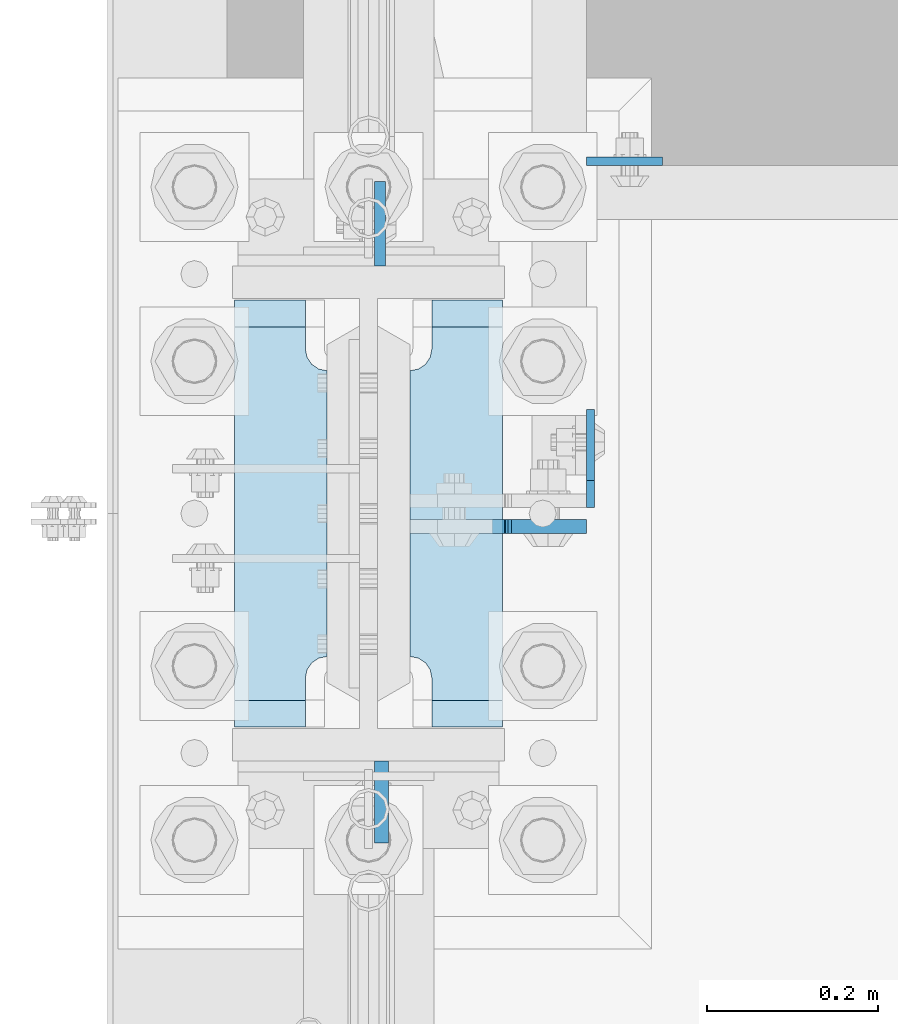
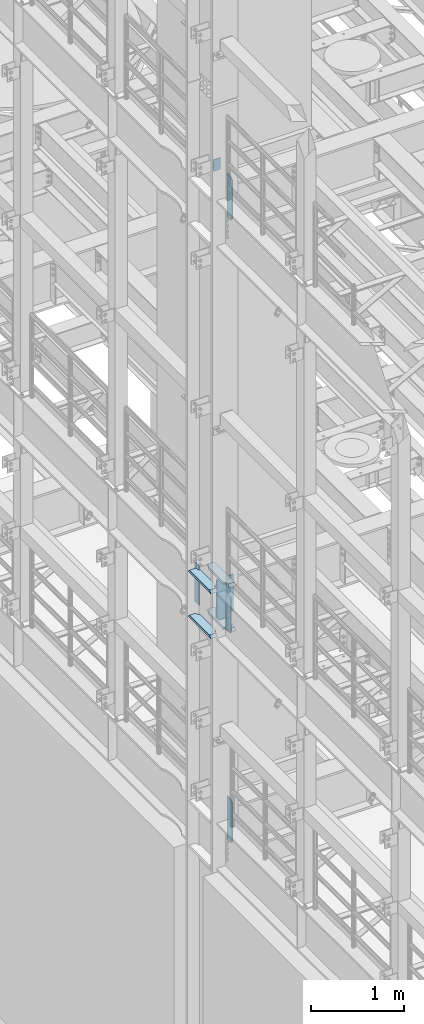
# One storey, part 1551 of 1876: 10 plates, 4 elements without a shape of their own.
"""IFC2X3 building model written with IfcOpenShell, lengths in millimetres."""

from ifc_helpers import new_model, si_unit, frame, origin_with_axes, place, context, subcontext, project, spatial, faceted_brep, material, type_object, element, aggregate, save


model = new_model("IFC2X3")

# Units and contexts
model_context = context("Model", 3, precision=1e-05, world=origin_with_axes())
body_context = subcontext(model_context, "Body", "Model", "MODEL_VIEW")
ifc_project = project(units=[si_unit("LENGTHUNIT", "METRE", prefix="MILLI"), si_unit("AREAUNIT", "SQUARE_METRE"), si_unit("VOLUMEUNIT", "CUBIC_METRE"), si_unit("MASSUNIT", "GRAM", prefix="KILO"), si_unit("TIMEUNIT", "SECOND"), si_unit("PLANEANGLEUNIT", "RADIAN"), si_unit("SOLIDANGLEUNIT", "STERADIAN"), si_unit("THERMODYNAMICTEMPERATUREUNIT", "DEGREE_CELSIUS"), si_unit("LUMINOUSINTENSITYUNIT", "LUMEN")], contexts=[model_context])

# Site, building, storey
site_placement = place(None, origin_with_axes())
site = spatial("IfcSite", under=ifc_project, at=site_placement, CompositionType="ELEMENT")
building_placement = place(site_placement, origin_with_axes())
building = spatial("IfcBuilding", under=site, at=building_placement, Name="Undefined", CompositionType="ELEMENT")
storey_placement = place(building_placement, origin_with_axes())
storey = spatial("IfcBuildingStorey", under=building, at=storey_placement, Name="Undefined", CompositionType="ELEMENT", Elevation=0.0)

# Assembly, plate
assembly_1_placement = place(storey_placement, origin_with_axes())
assembly_1 = element("IfcElementAssembly", 1, at=assembly_1_placement, inside=storey, Name="BEAM", AssemblyPlace="NOTDEFINED", PredefinedType="RIGID_FRAME")
ifc_material_1 = material(Name="STEEL/A36")
plate_type_1 = type_object("IfcPlateType", PredefinedType="NOTDEFINED")
plate_1_placement = place(assembly_1_placement, frame((254.0, 1935.1625, 13284.2), z_axis=(1.0, 0.0, 0.0), x_axis=(0.0, 0.0, -1.0)))
plate_1 = element("IfcPlate", 2, at=plate_1_placement, type_object=plate_type_1, material=ifc_material_1, Name="PLATE", context=body_context, shape_type="Brep", body=[
    faceted_brep([(0.0, -4.76249999999982, 0.0), (0.0, -4.76249999999982, 88.9000015258789), (0.0, 4.76249999999982, 88.9000015258789), (0.0, 4.76249999999982, 0.0), (152.399993896484, -4.76249999999982, 88.9000015258789), (152.399993896484, 4.76249999999982, 88.9000015258789), (152.399993896484, -4.76249999999982, 0.0), (152.399993896484, 4.76249999999982, 0.0)], [[[0, 1, 2, 3]], [[1, 4, 5, 2]], [[4, 6, 7, 5]], [[6, 0, 3, 7]], [[5, 7, 3, 2]], [[6, 4, 1, 0]]]),
])
aggregate(assembly_1, [plate_1])

assembly_2_placement = place(storey_placement, origin_with_axes())
assembly_2 = element("IfcElementAssembly", 3, at=assembly_2_placement, inside=storey, Name="COLUMN", AssemblyPlace="NOTDEFINED", PredefinedType="RIGID_FRAME")
ifc_material_2 = material(Name="STEEL/A572-50")
plate_type_2 = type_object("IfcPlateType", PredefinedType="NOTDEFINED")
plate_2_placement = place(assembly_2_placement, frame((13.493000125885, 1812.925, 8099.425), z_axis=(0.0, 1.0, 0.0), x_axis=(0.0, 0.0, -1.0)))
plate_2 = element("IfcPlate", 4, at=plate_2_placement, type_object=plate_type_2, material=ifc_material_2, Name="PLATE", context=body_context, shape_type="Brep", body=[
    faceted_brep([(0.0, -6.35000000000036, 0.0), (0.0, -6.34999999999991, 98.4250030517578), (0.0, 6.34999999999991, 98.4250030517578), (0.0, 6.35000000000036, 0.0), (514.349975585938, -6.35000000000036, 98.4250030517578), (514.349975585938, 6.35000000000036, 98.4250030517578), (514.349975585938, -6.35000000000036, 0.0), (514.349975585938, 6.35000000000036, 0.0)], [[[0, 1, 2, 3]], [[1, 4, 5, 2]], [[4, 6, 7, 5]], [[6, 0, 3, 7]], [[5, 7, 3, 2]], [[6, 4, 1, 0]]]),
])

assembly_3_placement = place(storey_placement, origin_with_axes())
assembly_3 = element("IfcElementAssembly", 5, at=assembly_3_placement, inside=storey, Name="BEAM", AssemblyPlace="NOTDEFINED", PredefinedType="RIGID_FRAME")
plate_type_3 = type_object("IfcPlateType", PredefinedType="NOTDEFINED")
plate_3_placement = place(assembly_3_placement, frame((258.762999916077, 1531.14375, 4535.4875), z_axis=(0.0, 0.0, 1.0), x_axis=(0.0, 1.0, 0.0)))
plate_3 = element("IfcPlate", 6, at=plate_3_placement, type_object=plate_type_3, material=ifc_material_1, Name="PLATE", context=body_context, shape_type="Brep", body=[
    faceted_brep([(-9.76996261670138e-14, -4.76250000000073, 31.75), (0.0, -4.76249999999999, 538.162475585938), (0.0, 4.76249999999999, 538.162475585938), (-9.76996261670138e-14, 4.76250000000073, 31.75), (31.75, -4.76249999999999, 569.912475585938), (31.75, 4.76249999999999, 569.912475585938), (114.300003051758, -4.76249999999999, 569.912475585938), (114.300003051758, 4.76249999999999, 569.912475585938), (114.300003051758, -4.76249999999999, 0.0), (114.300003051758, 4.76249999999999, 0.0), (31.75, -4.76250000000073, 0.0), (31.75, 4.76250000000073, 0.0)], [[[0, 1, 2, 3]], [[1, 4, 5, 2]], [[4, 6, 7, 5]], [[6, 8, 9, 7]], [[8, 10, 11, 9]], [[10, 0, 3, 11]], [[5, 7, 9, 11, 3, 2]], [[10, 8, 6, 4, 1, 0]]]),
])
aggregate(assembly_3, [plate_3])

assembly_4_placement = place(storey_placement, origin_with_axes())
assembly_4 = element("IfcElementAssembly", 7, at=assembly_4_placement, inside=storey, Name="BEAM", AssemblyPlace="NOTDEFINED", PredefinedType="RIGID_FRAME")
plate_4_placement = place(assembly_4_placement, frame((258.762999916077, 1531.14375, 12714.2875), z_axis=(0.0, 0.0, 1.0), x_axis=(0.0, 1.0, 0.0)))
plate_4 = element("IfcPlate", 8, at=plate_4_placement, type_object=plate_type_3, material=ifc_material_1, Name="PLATE", context=body_context, shape_type="Brep", body=[
    faceted_brep([(-9.76996261670138e-14, -4.76250000000073, 31.75), (0.0, -4.76249999999999, 538.162475585938), (0.0, 4.76249999999999, 538.162475585938), (-9.76996261670138e-14, 4.76250000000073, 31.75), (31.75, -4.76249999999999, 569.912475585938), (31.75, 4.76249999999999, 569.912475585938), (114.300003051758, -4.76249999999999, 569.912475585938), (114.300003051758, 4.76249999999999, 569.912475585938), (114.300003051758, -4.76249999999999, 0.0), (114.300003051758, 4.76249999999999, 0.0), (31.75, -4.76250000000073, 0.0), (31.75, 4.76250000000073, 0.0)], [[[0, 1, 2, 3]], [[1, 4, 5, 2]], [[4, 6, 7, 5]], [[6, 8, 9, 7]], [[8, 10, 11, 9]], [[10, 0, 3, 11]], [[5, 7, 9, 11, 3, 2]], [[10, 8, 6, 4, 1, 0]]]),
])
aggregate(assembly_4, [plate_4])

# Plate
plate_type_4 = type_object("IfcPlateType", PredefinedType="NOTDEFINED")
plate_5_placement = place(assembly_2_placement, frame((15.080500125885, 1235.075, 8089.9), z_axis=(0.0, -1.0, 0.0), x_axis=(0.0, 0.0, -1.0)))
plate_5 = element("IfcPlate", 9, at=plate_5_placement, type_object=plate_type_4, material=ifc_material_1, Name="PLATE", context=body_context, shape_type="Brep", body=[
    faceted_brep([(0.0, -7.9375, 0.0), (0.0, -7.9375, 95.25), (0.0, 7.9375, 95.25), (0.0, 7.9375, 0.0), (457.200012207031, -7.9375, 95.25), (457.200012207031, 7.9375, 95.25), (457.200012207031, -7.9375, 0.0), (457.200012207031, 7.9375, 0.0)], [[[0, 1, 2, 3]], [[1, 4, 5, 2]], [[4, 6, 7, 5]], [[6, 0, 3, 7]], [[5, 7, 3, 2]], [[6, 4, 1, 0]]]),
])

plate_type_5 = type_object("IfcPlateType", PredefinedType="NOTDEFINED")
plate_6_placement = place(assembly_2_placement, frame((-48.41875, 1274.7625, 7546.97501220703), z_axis=(0.0, 1.0, 0.0), x_axis=(-1.0, 0.0, 0.0)))
plate_6 = element("IfcPlate", 10, at=plate_6_placement, type_object=plate_type_5, material=ifc_material_2, Name="PLATE", context=body_context, shape_type="Brep", body=[
    faceted_brep([(107.949996948242, -15.875, 498.475006103516), (107.949996948242, 15.875, 467.025007631571), (25.3999996185303, 15.875, 467.025007631571), (25.3999996185303, -15.875, 498.475006103516), (23.4665397733561, -15.875, 431.604843634198), (25.3999996185303, -15.875, 441.325002670288), (25.3999996185303, 15.875, 441.325002670288), (23.4665397733561, 15.875, 431.604843634198), (17.9605119724001, -15.875, 423.36449069789), (17.9605119724001, 15.875, 423.36449069789), (9.72015903609281, -15.875, 417.858462896934), (9.72015903609281, 15.875, 417.858462896934), (0.0, -15.875, 415.925003051758), (0.0, 15.875, 415.925003051758), (0.0, -15.875, 82.5500030517578), (0.0, 15.875, 82.5500030517578), (9.72015903609099, -15.875, 80.616543206582), (9.72015903609099, 15.875, 80.616543206582), (17.9605119723983, -15.875, 75.1105154056258), (17.9605119723983, 15.875, 75.1105154056258), (23.4665397733552, -15.875, 66.8701624693183), (23.4665397733552, 15.875, 66.8701624693183), (25.3999996185303, -15.875, 57.1500034332275), (25.3999996185303, 15.875, 57.1500034332275), (25.3999996185303, 15.875, 31.449998471945), (25.3999996185303, -15.875, 0.0), (107.949996948242, 15.875, 31.449998471945), (107.949996948242, -15.875, 0.0)], [[[0, 1, 2, 3]], [[4, 5, 6, 7]], [[8, 4, 7, 9]], [[10, 8, 9, 11]], [[12, 10, 11, 13]], [[14, 12, 13, 15]], [[16, 14, 15, 17]], [[18, 16, 17, 19]], [[20, 18, 19, 21]], [[22, 20, 21, 23]], [[22, 23, 24, 25]], [[26, 27, 25, 24]], [[5, 4, 8, 10, 12, 14, 16, 18, 20, 22, 25, 27, 0, 3]], [[6, 5, 3, 2]], [[26, 24, 23, 21, 19, 17, 15, 13, 11, 9, 7, 6, 2, 1]], [[27, 26, 1, 0]]]),
])

plate_7_placement = place(assembly_2_placement, frame((-48.41875, 1274.7625, 8137.525), z_axis=(0.0, 1.0, 0.0), x_axis=(-1.0, 0.0, 0.0)))
plate_7 = element("IfcPlate", 11, at=plate_7_placement, type_object=plate_type_5, material=ifc_material_2, Name="PLATE", context=body_context, shape_type="Brep", body=[
    faceted_brep([(107.949996948242, -15.875, 498.475006103516), (107.949996948242, 15.875, 467.025007631571), (25.3999996185303, 15.875, 467.025007631571), (25.3999996185303, -15.875, 498.475006103516), (23.4665397733561, -15.875, 431.604843634198), (25.3999996185303, -15.875, 441.325002670288), (25.3999996185303, 15.875, 441.325002670288), (23.4665397733561, 15.875, 431.604843634198), (17.9605119724001, -15.875, 423.36449069789), (17.9605119724001, 15.875, 423.36449069789), (9.72015903609281, -15.875, 417.858462896934), (9.72015903609281, 15.875, 417.858462896934), (0.0, -15.875, 415.925003051758), (0.0, 15.875, 415.925003051758), (0.0, -15.875, 82.5500030517578), (0.0, 15.875, 82.5500030517578), (9.72015903609099, -15.875, 80.616543206582), (9.72015903609099, 15.875, 80.616543206582), (17.9605119723983, -15.875, 75.1105154056258), (17.9605119723983, 15.875, 75.1105154056258), (23.4665397733552, -15.875, 66.8701624693183), (23.4665397733552, 15.875, 66.8701624693183), (25.3999996185303, -15.875, 57.1500034332275), (25.3999996185303, 15.875, 57.1500034332275), (25.3999996185303, 15.875, 31.449998471945), (25.3999996185303, -15.875, 0.0), (107.949996948242, 15.875, 31.449998471945), (107.949996948242, -15.875, 0.0)], [[[0, 1, 2, 3]], [[4, 5, 6, 7]], [[8, 4, 7, 9]], [[10, 8, 9, 11]], [[12, 10, 11, 13]], [[14, 12, 13, 15]], [[16, 14, 15, 17]], [[18, 16, 17, 19]], [[20, 18, 19, 21]], [[22, 20, 21, 23]], [[22, 23, 24, 25]], [[26, 27, 25, 24]], [[5, 4, 8, 10, 12, 14, 16, 18, 20, 22, 25, 27, 0, 3]], [[6, 5, 3, 2]], [[26, 24, 23, 21, 19, 17, 15, 13, 11, 9, 7, 6, 2, 1]], [[27, 26, 1, 0]]]),
])

plate_8_placement = place(assembly_2_placement, frame((156.36875, 1274.7625, 7546.97501220703), z_axis=(0.0, 1.0, 0.0), x_axis=(-1.0, 0.0, 0.0)))
plate_8 = element("IfcPlate", 12, at=plate_8_placement, type_object=plate_type_5, material=ifc_material_2, Name="PLATE", context=body_context, shape_type="Brep", body=[
    faceted_brep([(82.5499973297119, -15.875, 498.475006103516), (82.5499973297119, 15.875, 467.025007631571), (0.0, 15.875, 467.025007631571), (0.0, -15.875, 498.475006103516), (82.5499973297119, 15.875, 31.449998471945), (82.5499973297119, -15.875, 0.0), (0.0, -15.875, 0.0), (0.0, 15.875, 31.449998471945), (82.5499973297119, 15.875, 57.1500034332275), (82.5499973297119, -15.875, 57.1500034332275), (84.4834571748879, -15.875, 66.8701624693188), (84.4834571748879, 15.875, 66.8701624693188), (89.9894849758439, -15.875, 75.1105154056261), (89.9894849758439, 15.875, 75.1105154056261), (98.2298379121512, -15.875, 80.616543206582), (98.2298379121512, 15.875, 80.616543206582), (107.949996948242, -15.875, 82.5500030517578), (107.949996948242, 15.875, 82.5500030517578), (107.949996948242, -15.875, 415.925003051758), (107.949996948242, 15.875, 415.925003051758), (98.2298379121512, -15.875, 417.858462896934), (98.2298379121512, 15.875, 417.858462896934), (89.9894849758439, -15.875, 423.36449069789), (89.9894849758439, 15.875, 423.36449069789), (84.483457174887, -15.875, 431.604843634197), (84.483457174887, 15.875, 431.604843634197), (82.5499973297119, -15.875, 441.325002670288), (82.5499973297119, 15.875, 441.325002670288)], [[[0, 1, 2, 3]], [[4, 5, 6, 7]], [[8, 9, 5, 4]], [[10, 9, 8, 11]], [[12, 10, 11, 13]], [[14, 12, 13, 15]], [[16, 14, 15, 17]], [[18, 16, 17, 19]], [[20, 18, 19, 21]], [[22, 20, 21, 23]], [[24, 22, 23, 25]], [[26, 24, 25, 27]], [[6, 5, 9, 10, 12, 14, 16, 18, 20, 22, 24, 26, 0, 3]], [[7, 6, 3, 2]], [[27, 25, 23, 21, 19, 17, 15, 13, 11, 8, 4, 7, 2, 1]], [[26, 27, 1, 0]]]),
])

plate_9_placement = place(assembly_2_placement, frame((156.36875, 1274.7625, 8137.525), z_axis=(0.0, 1.0, 0.0), x_axis=(-1.0, 0.0, 0.0)))
plate_9 = element("IfcPlate", 13, at=plate_9_placement, type_object=plate_type_5, material=ifc_material_2, Name="PLATE", context=body_context, shape_type="Brep", body=[
    faceted_brep([(82.5499973297119, -15.875, 498.475006103516), (82.5499973297119, 15.875, 467.025007631571), (0.0, 15.875, 467.025007631571), (0.0, -15.875, 498.475006103516), (82.5499973297119, 15.875, 31.449998471945), (82.5499973297119, -15.875, 0.0), (0.0, -15.875, 0.0), (0.0, 15.875, 31.449998471945), (82.5499973297119, 15.875, 57.1500034332275), (82.5499973297119, -15.875, 57.1500034332275), (84.4834571748879, -15.875, 66.8701624693188), (84.4834571748879, 15.875, 66.8701624693188), (89.9894849758439, -15.875, 75.1105154056261), (89.9894849758439, 15.875, 75.1105154056261), (98.2298379121512, -15.875, 80.616543206582), (98.2298379121512, 15.875, 80.616543206582), (107.949996948242, -15.875, 82.5500030517578), (107.949996948242, 15.875, 82.5500030517578), (107.949996948242, -15.875, 415.925003051758), (107.949996948242, 15.875, 415.925003051758), (98.2298379121512, -15.875, 417.858462896934), (98.2298379121512, 15.875, 417.858462896934), (89.9894849758439, -15.875, 423.36449069789), (89.9894849758439, 15.875, 423.36449069789), (84.483457174887, -15.875, 431.604843634197), (84.483457174887, 15.875, 431.604843634197), (82.5499973297119, -15.875, 441.325002670288), (82.5499973297119, 15.875, 441.325002670288)], [[[0, 1, 2, 3]], [[4, 5, 6, 7]], [[8, 9, 5, 4]], [[10, 9, 8, 11]], [[12, 10, 11, 13]], [[14, 12, 13, 15]], [[16, 14, 15, 17]], [[18, 16, 17, 19]], [[20, 18, 19, 21]], [[22, 20, 21, 23]], [[24, 22, 23, 25]], [[26, 24, 25, 27]], [[6, 5, 9, 10, 12, 14, 16, 18, 20, 22, 24, 26, 0, 3]], [[7, 6, 3, 2]], [[27, 25, 23, 21, 19, 17, 15, 13, 11, 8, 4, 7, 2, 1]], [[26, 27, 1, 0]]]),
])

plate_type_6 = type_object("IfcPlateType", PredefinedType="NOTDEFINED")
plate_10_placement = place(assembly_2_placement, frame((48.4187500000001, 1508.91875, 8121.65), z_axis=(1.0, 0.0, 0.0), x_axis=(0.0, 0.0, -1.0)))
plate_10 = element("IfcPlate", 14, at=plate_10_placement, type_object=plate_type_6, material=ifc_material_1, Name="PLATE", context=body_context, shape_type="Brep", body=[
    faceted_brep([(501.650012207032, -7.9375, 205.581252728631), (501.650012207032, -7.9375, 123.031246757509), (501.650012207032, 7.9375, 123.031246757509), (501.650012207032, 7.9375, 205.581253051758), (502.61674212962, -7.9375, 118.171167239463), (502.61674212962, 7.9375, 118.171167239463), (505.369756030097, -7.9375, 114.050990771309), (505.369756030097, 7.9375, 114.050990771309), (509.489932498251, -7.9375, 111.297976870831), (509.489932498251, 7.9375, 111.297976870831), (514.350012016297, -7.9375, 110.331246948243), (514.350012016297, 7.9375, 110.331246948243), (558.799987792969, -7.9375, 110.331246948243), (558.799987792969, 7.9375, 110.331246948243), (19.0499992370605, -7.9375, 205.58125), (19.0499992370605, 7.9375, 205.581253051758), (19.0499992370605, 7.9375, 123.031249809265), (19.0499992370605, -7.9375, 123.031249809265), (18.083269314473, 7.9375, 118.17117029122), (18.083269314473, -7.9375, 118.17117029122), (15.3302554139955, 7.9375, 114.050993823066), (15.3302554139955, -7.9375, 114.050993823066), (11.2100789458418, 7.9375, 111.297979922588), (11.2100789458418, -7.9375, 111.297979922588), (6.34999942779541, 7.9375, 110.33125), (6.34999942779541, -7.9375, 110.33125), (0.0, 7.9375, 110.33125), (0.0, -7.9375, 110.33125), (0.0, 7.93749999999999, 31.75), (0.0, -7.93749999999998, 31.75), (31.75, -7.93749999999998, 0.0), (31.75, 7.93749999999999, 0.0), (527.049987792969, -7.93749999999998, 0.0), (527.049987792969, 7.93749999999999, 0.0), (558.799987792969, -7.93749999999998, 31.75), (558.799987792969, 7.93749999999999, 31.75)], [[[0, 1, 2, 3]], [[4, 5, 2, 1]], [[6, 7, 5, 4]], [[8, 9, 7, 6]], [[10, 11, 9, 8]], [[12, 13, 11, 10]], [[14, 15, 16, 17]], [[17, 16, 18, 19]], [[19, 18, 20, 21]], [[21, 20, 22, 23]], [[23, 22, 24, 25]], [[25, 24, 26, 27]], [[28, 29, 27, 26]], [[30, 29, 28, 31]], [[32, 30, 31, 33]], [[34, 32, 33, 35]], [[8, 6, 4, 1, 0, 14, 17, 19, 21, 23, 25, 27, 29, 30, 32, 34, 12, 10]], [[15, 14, 0, 3]], [[35, 33, 31, 28, 26, 24, 22, 20, 18, 16, 15, 3, 2, 5, 7, 9, 11, 13]], [[34, 35, 13, 12]]]),
])

aggregate(assembly_2, [plate_5, plate_2, plate_6, plate_7, plate_8, plate_9, plate_10])

save(model, "model.ifc")
